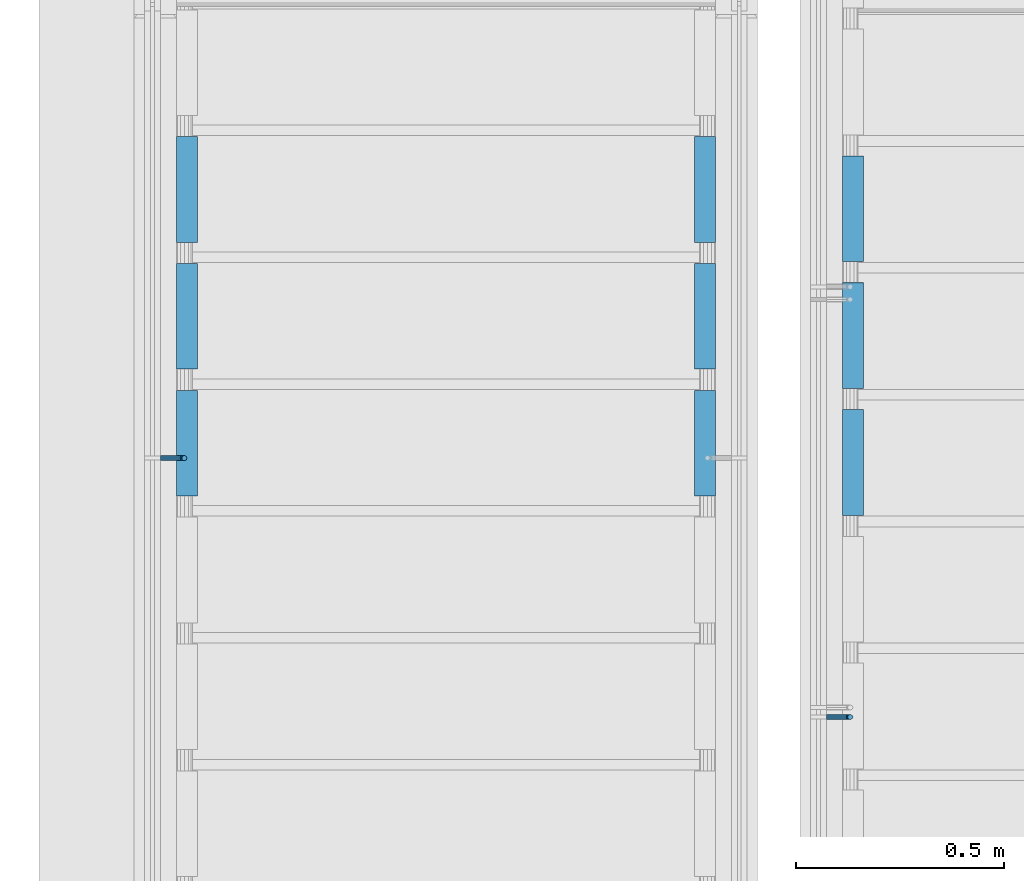
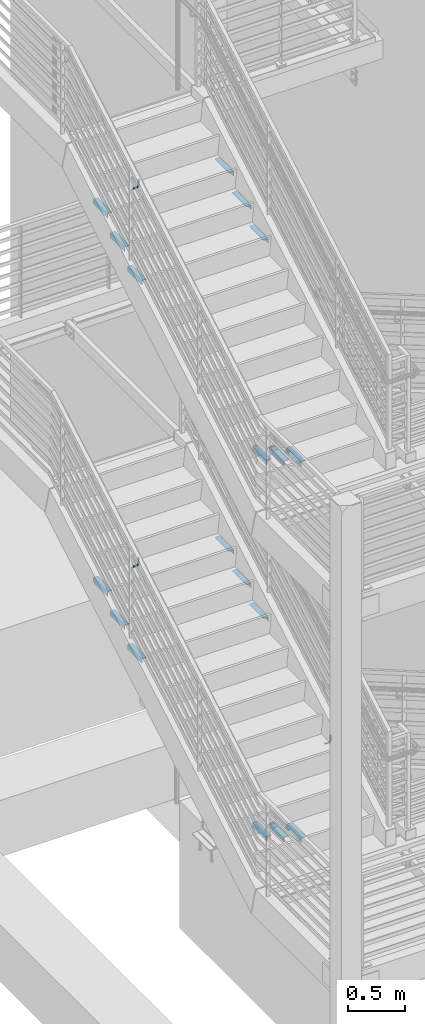
# One storey, part 861 of 1179: 21 beams, 7 elements without a shape of their own.
"""IFC2X3 building model written with IfcOpenShell, lengths in millimetres."""

from ifc_helpers import new_model, si_unit, frame, origin_with_axes, place, context, subcontext, project, spatial, faceted_brep, material, type_object, element, aggregate, save


model = new_model("IFC2X3")

# Units and contexts
model_context = context("Model", 3, precision=1e-05, world=origin_with_axes())
body_context = subcontext(model_context, "Body", "Model", "MODEL_VIEW")
ifc_project = project(units=[si_unit("LENGTHUNIT", "METRE", prefix="MILLI"), si_unit("AREAUNIT", "SQUARE_METRE"), si_unit("VOLUMEUNIT", "CUBIC_METRE"), si_unit("MASSUNIT", "GRAM", prefix="KILO"), si_unit("TIMEUNIT", "SECOND"), si_unit("PLANEANGLEUNIT", "RADIAN"), si_unit("SOLIDANGLEUNIT", "STERADIAN"), si_unit("THERMODYNAMICTEMPERATUREUNIT", "DEGREE_CELSIUS"), si_unit("LUMINOUSINTENSITYUNIT", "LUMEN")], contexts=[model_context])

# Site, building, storey
site_placement = place(None, origin_with_axes())
site = spatial("IfcSite", under=ifc_project, at=site_placement, CompositionType="ELEMENT")
building_placement = place(site_placement, origin_with_axes())
building = spatial("IfcBuilding", under=site, at=building_placement, Name="Undefined", CompositionType="ELEMENT")
storey_placement = place(building_placement, origin_with_axes())
storey = spatial("IfcBuildingStorey", under=building, at=storey_placement, Name="Undefined", CompositionType="ELEMENT", Elevation=0.0)

# Assembly, beams
assembly_1_placement = place(storey_placement, origin_with_axes())
assembly_1 = element("IfcElementAssembly", 1, at=assembly_1_placement, inside=storey, Name="STRINGER", AssemblyPlace="NOTDEFINED", PredefinedType="RIGID_FRAME")
ifc_material = material(Name="STEEL/A36")
beam_type_1 = type_object("IfcBeamType", Name="L2X2X3/16", PredefinedType="NOTDEFINED")
beam_1_placement = place(assembly_1_placement, frame((-3174.99999998093, 34376.6643775512, 7712.07500000067), z_axis=(1.0, 0.0, 0.0), x_axis=(0.0, 1.0, 0.0)))
beam_1 = element("IfcBeam", 2, at=beam_1_placement, type_object=beam_type_1, material=ifc_material, Name="ANGLE", ObjectType="L2X2X3/16", context=body_context, shape_type="Brep", body=[
    faceted_brep([(0.0, 25.3999999999996, -25.4000000000015), (0.0, 25.3999999999996, 25.4000000000015), (254.0, 25.3999999999996, 25.4000000000001), (254.0, 25.3999999999996, -25.4000000000001), (0.0, 20.6374999999998, 25.4000000000015), (254.0, 20.6374999999998, 25.4000000000001), (0.0, 20.6374999999998, -20.6374999999971), (254.0, 20.6374999999998, -20.6374999999998), (0.0, -25.3999999999996, -20.6374999999971), (254.0, -25.3999999999996, -20.6374999999998), (0.0, -25.3999999999996, -25.4000000000015), (254.0, -25.3999999999996, -25.4000000000001)], [[[0, 1, 2, 3]], [[1, 4, 5, 2]], [[4, 6, 7, 5]], [[6, 8, 9, 7]], [[8, 10, 11, 9]], [[10, 0, 3, 11]], [[5, 7, 9, 11, 3, 2]], [[10, 8, 6, 4, 1, 0]]]),
])
beam_2_placement = place(assembly_1_placement, frame((-1930.40000000014, 34630.6643775512, 7712.07499999954), z_axis=(-1.0, 0.0, 0.0), x_axis=(0.0, -1.0, 0.0)))
beam_2 = element("IfcBeam", 3, at=beam_2_placement, type_object=beam_type_1, material=ifc_material, Name="ANGLE", ObjectType="L2X2X3/16", context=body_context, shape_type="Brep", body=[
    faceted_brep([(0.0, 25.3999999999996, -25.4000000000015), (0.0, 25.3999999999996, 25.4000000000015), (254.0, 25.3999999999996, 25.4000000000001), (254.0, 25.3999999999996, -25.4000000000001), (0.0, 20.6374999999998, 25.4000000000015), (254.0, 20.6374999999998, 25.4000000000001), (0.0, 20.6374999999998, -20.6374999999971), (254.0, 20.6374999999998, -20.6374999999998), (0.0, -25.3999999999996, -20.6374999999971), (254.0, -25.3999999999996, -20.6374999999998), (0.0, -25.3999999999996, -25.4000000000015), (254.0, -25.3999999999996, -25.4000000000001)], [[[0, 1, 2, 3]], [[1, 4, 5, 2]], [[4, 6, 7, 5]], [[6, 8, 9, 7]], [[8, 10, 11, 9]], [[10, 0, 3, 11]], [[5, 7, 9, 11, 3, 2]], [[10, 8, 6, 4, 1, 0]]]),
])
beam_3_placement = place(assembly_1_placement, frame((-3174.99999998109, 34071.8643778032, 7534.27500000067), z_axis=(1.0, 0.0, 0.0), x_axis=(0.0, 1.0, 0.0)))
beam_3 = element("IfcBeam", 4, at=beam_3_placement, type_object=beam_type_1, material=ifc_material, Name="ANGLE", ObjectType="L2X2X3/16", context=body_context, shape_type="Brep", body=[
    faceted_brep([(0.0, 25.3999999999996, -25.4000000000015), (0.0, 25.3999999999996, 25.4000000000015), (254.0, 25.3999999999996, 25.4000000000001), (254.0, 25.3999999999996, -25.4000000000001), (0.0, 20.6374999999998, 25.4000000000015), (254.0, 20.6374999999998, 25.4000000000001), (0.0, 20.6374999999998, -20.6374999999971), (254.0, 20.6374999999998, -20.6374999999998), (0.0, -25.3999999999996, -20.6374999999971), (254.0, -25.3999999999996, -20.6374999999998), (0.0, -25.3999999999996, -25.4000000000015), (254.0, -25.3999999999996, -25.4000000000001)], [[[0, 1, 2, 3]], [[1, 4, 5, 2]], [[4, 6, 7, 5]], [[6, 8, 9, 7]], [[8, 10, 11, 9]], [[10, 0, 3, 11]], [[5, 7, 9, 11, 3, 2]], [[10, 8, 6, 4, 1, 0]]]),
])
beam_4_placement = place(assembly_1_placement, frame((-1930.4000000003, 34325.8643778032, 7534.27499999954), z_axis=(-1.0, 0.0, 0.0), x_axis=(0.0, -1.0, 0.0)))
beam_4 = element("IfcBeam", 5, at=beam_4_placement, type_object=beam_type_1, material=ifc_material, Name="ANGLE", ObjectType="L2X2X3/16", context=body_context, shape_type="Brep", body=[
    faceted_brep([(0.0, 25.3999999999996, -25.4000000000015), (0.0, 25.3999999999996, 25.4000000000015), (254.0, 25.3999999999996, 25.4000000000001), (254.0, 25.3999999999996, -25.4000000000001), (0.0, 20.6374999999998, 25.4000000000015), (254.0, 20.6374999999998, 25.4000000000001), (0.0, 20.6374999999998, -20.6374999999971), (254.0, 20.6374999999998, -20.6374999999998), (0.0, -25.3999999999996, -20.6374999999971), (254.0, -25.3999999999996, -20.6374999999998), (0.0, -25.3999999999996, -25.4000000000015), (254.0, -25.3999999999996, -25.4000000000001)], [[[0, 1, 2, 3]], [[1, 4, 5, 2]], [[4, 6, 7, 5]], [[6, 8, 9, 7]], [[8, 10, 11, 9]], [[10, 0, 3, 11]], [[5, 7, 9, 11, 3, 2]], [[10, 8, 6, 4, 1, 0]]]),
])
beam_5_placement = place(assembly_1_placement, frame((-3174.99999998125, 33767.0643780553, 7356.47500000067), z_axis=(1.0, 0.0, 0.0), x_axis=(0.0, 1.0, 0.0)))
beam_5 = element("IfcBeam", 6, at=beam_5_placement, type_object=beam_type_1, material=ifc_material, Name="ANGLE", ObjectType="L2X2X3/16", context=body_context, shape_type="Brep", body=[
    faceted_brep([(0.0, 25.3999999999996, -25.4000000000015), (0.0, 25.3999999999996, 25.4000000000015), (254.0, 25.3999999999996, 25.4000000000001), (254.0, 25.3999999999996, -25.4000000000001), (0.0, 20.6374999999998, 25.4000000000015), (254.0, 20.6374999999998, 25.4000000000001), (0.0, 20.6374999999998, -20.6374999999971), (254.0, 20.6374999999998, -20.6374999999998), (0.0, -25.3999999999996, -20.6374999999971), (254.0, -25.3999999999996, -20.6374999999998), (0.0, -25.3999999999996, -25.4000000000015), (254.0, -25.3999999999996, -25.4000000000001)], [[[0, 1, 2, 3]], [[1, 4, 5, 2]], [[4, 6, 7, 5]], [[6, 8, 9, 7]], [[8, 10, 11, 9]], [[10, 0, 3, 11]], [[5, 7, 9, 11, 3, 2]], [[10, 8, 6, 4, 1, 0]]]),
])
beam_6_placement = place(assembly_1_placement, frame((-1930.40000000046, 34021.0643780553, 7356.47499999954), z_axis=(-1.0, 0.0, 0.0), x_axis=(0.0, -1.0, 0.0)))
beam_6 = element("IfcBeam", 7, at=beam_6_placement, type_object=beam_type_1, material=ifc_material, Name="ANGLE", ObjectType="L2X2X3/16", context=body_context, shape_type="Brep", body=[
    faceted_brep([(0.0, 25.3999999999996, -25.4000000000015), (0.0, 25.3999999999996, 25.4000000000015), (254.0, 25.3999999999996, 25.4000000000001), (254.0, 25.3999999999996, -25.4000000000001), (0.0, 20.6374999999998, 25.4000000000015), (254.0, 20.6374999999998, 25.4000000000001), (0.0, 20.6374999999998, -20.6374999999971), (254.0, 20.6374999999998, -20.6374999999998), (0.0, -25.3999999999996, -20.6374999999971), (254.0, -25.3999999999996, -20.6374999999998), (0.0, -25.3999999999996, -25.4000000000015), (254.0, -25.3999999999996, -25.4000000000001)], [[[0, 1, 2, 3]], [[1, 4, 5, 2]], [[4, 6, 7, 5]], [[6, 8, 9, 7]], [[8, 10, 11, 9]], [[10, 0, 3, 11]], [[5, 7, 9, 11, 3, 2]], [[10, 8, 6, 4, 1, 0]]]),
])
aggregate(assembly_1, [beam_1, beam_2, beam_3, beam_4, beam_5, beam_6])

assembly_2_placement = place(storey_placement, origin_with_axes())
assembly_2 = element("IfcElementAssembly", 8, at=assembly_2_placement, inside=storey, Name="STRINGER", AssemblyPlace="NOTDEFINED", PredefinedType="RIGID_FRAME")
beam_7_placement = place(assembly_2_placement, frame((-1574.79999999983, 33720.7356224165, 4867.27499923021), z_axis=(1.0, 0.0, 0.0), x_axis=(0.0, 1.0, 0.0)))
beam_7 = element("IfcBeam", 9, at=beam_7_placement, type_object=beam_type_1, material=ifc_material, Name="ANGLE", ObjectType="L2X2X3/16", context=body_context, shape_type="Brep", body=[
    faceted_brep([(0.0, 25.3999999999996, -25.4000000000015), (0.0, 25.3999999999996, 25.4000000000015), (254.0, 25.3999999999996, 25.4000000000001), (254.0, 25.3999999999996, -25.4000000000001), (0.0, 20.6374999999998, 25.4000000000015), (254.0, 20.6374999999998, 25.4000000000001), (0.0, 20.6374999999998, -20.6374999999971), (254.0, 20.6374999999998, -20.6374999999998), (0.0, -25.3999999999996, -20.6374999999971), (254.0, -25.3999999999996, -20.6374999999998), (0.0, -25.3999999999996, -25.4000000000015), (254.0, -25.3999999999996, -25.4000000000001)], [[[0, 1, 2, 3]], [[1, 4, 5, 2]], [[4, 6, 7, 5]], [[6, 8, 9, 7]], [[8, 10, 11, 9]], [[10, 0, 3, 11]], [[5, 7, 9, 11, 3, 2]], [[10, 8, 6, 4, 1, 0]]]),
])
beam_8_placement = place(assembly_2_placement, frame((-1574.80000000188, 34025.5356223526, 4689.47499912051), z_axis=(1.0, 0.0, 0.0), x_axis=(0.0, 1.0, 0.0)))
beam_8 = element("IfcBeam", 10, at=beam_8_placement, type_object=beam_type_1, material=ifc_material, Name="ANGLE", ObjectType="L2X2X3/16", context=body_context, shape_type="Brep", body=[
    faceted_brep([(0.0, 25.3999999999996, -25.4000000000015), (0.0, 25.3999999999996, 25.4000000000015), (254.0, 25.3999999999996, 25.4000000000001), (254.0, 25.3999999999996, -25.4000000000001), (0.0, 20.6374999999998, 25.4000000000015), (254.0, 20.6374999999998, 25.4000000000001), (0.0, 20.6374999999998, -20.6374999999971), (254.0, 20.6374999999998, -20.6374999999998), (0.0, -25.3999999999996, -20.6374999999971), (254.0, -25.3999999999996, -20.6374999999998), (0.0, -25.3999999999996, -25.4000000000015), (254.0, -25.3999999999996, -25.4000000000001)], [[[0, 1, 2, 3]], [[1, 4, 5, 2]], [[4, 6, 7, 5]], [[6, 8, 9, 7]], [[8, 10, 11, 9]], [[10, 0, 3, 11]], [[5, 7, 9, 11, 3, 2]], [[10, 8, 6, 4, 1, 0]]]),
])
beam_9_placement = place(assembly_2_placement, frame((-1574.80000000394, 34330.3356222886, 4511.67499901081), z_axis=(1.0, 0.0, 0.0), x_axis=(0.0, 1.0, 0.0)))
beam_9 = element("IfcBeam", 11, at=beam_9_placement, type_object=beam_type_1, material=ifc_material, Name="ANGLE", ObjectType="L2X2X3/16", context=body_context, shape_type="Brep", body=[
    faceted_brep([(0.0, 25.3999999999996, -25.4000000000015), (0.0, 25.3999999999996, 25.4000000000015), (254.0, 25.3999999999996, 25.4000000000001), (254.0, 25.3999999999996, -25.4000000000001), (0.0, 20.6374999999998, 25.4000000000015), (254.0, 20.6374999999998, 25.4000000000001), (0.0, 20.6374999999998, -20.6374999999971), (254.0, 20.6374999999998, -20.6374999999998), (0.0, -25.3999999999996, -20.6374999999971), (254.0, -25.3999999999996, -20.6374999999998), (0.0, -25.3999999999996, -25.4000000000015), (254.0, -25.3999999999996, -25.4000000000001)], [[[0, 1, 2, 3]], [[1, 4, 5, 2]], [[4, 6, 7, 5]], [[6, 8, 9, 7]], [[8, 10, 11, 9]], [[10, 0, 3, 11]], [[5, 7, 9, 11, 3, 2]], [[10, 8, 6, 4, 1, 0]]]),
])
aggregate(assembly_2, [beam_7, beam_8, beam_9])

assembly_3_placement = place(storey_placement, origin_with_axes())
assembly_3 = element("IfcElementAssembly", 12, at=assembly_3_placement, inside=storey, Name="STRINGER", AssemblyPlace="NOTDEFINED", PredefinedType="RIGID_FRAME")
beam_10_placement = place(assembly_3_placement, frame((-1574.7999999795, 33720.6819391909, 803.029659879345), z_axis=(1.0, 0.0, 0.0), x_axis=(0.0, 1.0, 0.0)))
beam_10 = element("IfcBeam", 13, at=beam_10_placement, type_object=beam_type_1, material=ifc_material, Name="ANGLE", ObjectType="L2X2X3/16", context=body_context, shape_type="Brep", body=[
    faceted_brep([(0.0, 25.3999999999996, -25.4000000000015), (0.0, 25.3999999999996, 25.4000000000015), (254.0, 25.3999999999996, 25.4000000000001), (254.0, 25.3999999999996, -25.4000000000001), (0.0, 20.6374999999998, 25.4000000000015), (254.0, 20.6374999999998, 25.4000000000001), (0.0, 20.6374999999998, -20.6374999999971), (254.0, 20.6374999999998, -20.6374999999998), (0.0, -25.3999999999996, -20.6374999999971), (254.0, -25.3999999999996, -20.6374999999998), (0.0, -25.3999999999996, -25.4000000000015), (254.0, -25.3999999999996, -25.4000000000001)], [[[0, 1, 2, 3]], [[1, 4, 5, 2]], [[4, 6, 7, 5]], [[6, 8, 9, 7]], [[8, 10, 11, 9]], [[10, 0, 3, 11]], [[5, 7, 9, 11, 3, 2]], [[10, 8, 6, 4, 1, 0]]]),
])
beam_11_placement = place(assembly_3_placement, frame((-1574.79999997946, 34025.482092925, 626.547765742202), z_axis=(1.0, 0.0, 0.0), x_axis=(0.0, 1.0, 0.0)))
beam_11 = element("IfcBeam", 14, at=beam_11_placement, type_object=beam_type_1, material=ifc_material, Name="ANGLE", ObjectType="L2X2X3/16", context=body_context, shape_type="Brep", body=[
    faceted_brep([(0.0, 25.3999999999996, -25.4000000000015), (0.0, 25.3999999999996, 25.4000000000015), (254.0, 25.3999999999996, 25.4000000000001), (254.0, 25.3999999999996, -25.4000000000001), (0.0, 20.6374999999998, 25.4000000000015), (254.0, 20.6374999999998, 25.4000000000001), (0.0, 20.6374999999998, -20.6374999999971), (254.0, 20.6374999999998, -20.6374999999998), (0.0, -25.3999999999996, -20.6374999999971), (254.0, -25.3999999999996, -20.6374999999998), (0.0, -25.3999999999996, -25.4000000000015), (254.0, -25.3999999999996, -25.4000000000001)], [[[0, 1, 2, 3]], [[1, 4, 5, 2]], [[4, 6, 7, 5]], [[6, 8, 9, 7]], [[8, 10, 11, 9]], [[10, 0, 3, 11]], [[5, 7, 9, 11, 3, 2]], [[10, 8, 6, 4, 1, 0]]]),
])
beam_12_placement = place(assembly_3_placement, frame((-1574.79999997942, 34330.2822466591, 450.06587160506), z_axis=(1.0, 0.0, 0.0), x_axis=(0.0, 1.0, 0.0)))
beam_12 = element("IfcBeam", 15, at=beam_12_placement, type_object=beam_type_1, material=ifc_material, Name="ANGLE", ObjectType="L2X2X3/16", context=body_context, shape_type="Brep", body=[
    faceted_brep([(0.0, 25.3999999999996, -25.4000000000015), (0.0, 25.3999999999996, 25.4000000000015), (254.0, 25.3999999999996, 25.4000000000001), (254.0, 25.3999999999996, -25.4000000000001), (0.0, 20.6374999999998, 25.4000000000015), (254.0, 20.6374999999998, 25.4000000000001), (0.0, 20.6374999999998, -20.6374999999971), (254.0, 20.6374999999998, -20.6374999999998), (0.0, -25.3999999999996, -20.6374999999971), (254.0, -25.3999999999996, -20.6374999999998), (0.0, -25.3999999999996, -25.4000000000015), (254.0, -25.3999999999996, -25.4000000000001)], [[[0, 1, 2, 3]], [[1, 4, 5, 2]], [[4, 6, 7, 5]], [[6, 8, 9, 7]], [[8, 10, 11, 9]], [[10, 0, 3, 11]], [[5, 7, 9, 11, 3, 2]], [[10, 8, 6, 4, 1, 0]]]),
])
aggregate(assembly_3, [beam_10, beam_11, beam_12])

assembly_4_placement = place(storey_placement, origin_with_axes())
assembly_4 = element("IfcElementAssembly", 16, at=assembly_4_placement, inside=storey, Name="STRINGER", AssemblyPlace="NOTDEFINED", PredefinedType="RIGID_FRAME")
beam_13_placement = place(assembly_4_placement, frame((-3175.00000000384, 34376.719261414, 3626.64375000058), z_axis=(1.0, 0.0, 0.0), x_axis=(0.0, 1.0, 0.0)))
beam_13 = element("IfcBeam", 17, at=beam_13_placement, type_object=beam_type_1, material=ifc_material, Name="ANGLE", ObjectType="L2X2X3/16", context=body_context, shape_type="Brep", body=[
    faceted_brep([(0.0, 25.3999999999996, -25.4000000000015), (0.0, 25.3999999999996, 25.4000000000015), (254.0, 25.3999999999996, 25.4000000000001), (254.0, 25.3999999999996, -25.4000000000001), (0.0, 20.6374999999998, 25.4000000000015), (254.0, 20.6374999999998, 25.4000000000001), (0.0, 20.6374999999998, -20.6374999999971), (254.0, 20.6374999999998, -20.6374999999998), (0.0, -25.3999999999996, -20.6374999999971), (254.0, -25.3999999999996, -20.6374999999998), (0.0, -25.3999999999996, -25.4000000000015), (254.0, -25.3999999999996, -25.4000000000001)], [[[0, 1, 2, 3]], [[1, 4, 5, 2]], [[4, 6, 7, 5]], [[6, 8, 9, 7]], [[8, 10, 11, 9]], [[10, 0, 3, 11]], [[5, 7, 9, 11, 3, 2]], [[10, 8, 6, 4, 1, 0]]]),
])
beam_14_placement = place(assembly_4_placement, frame((-1930.40000000084, 34630.719261414, 3626.64375000058), z_axis=(-1.0, 0.0, 0.0), x_axis=(0.0, -1.0, 0.0)))
beam_14 = element("IfcBeam", 18, at=beam_14_placement, type_object=beam_type_1, material=ifc_material, Name="ANGLE", ObjectType="L2X2X3/16", context=body_context, shape_type="Brep", body=[
    faceted_brep([(0.0, 25.3999999999996, -25.4000000000015), (0.0, 25.3999999999996, 25.4000000000015), (254.0, 25.3999999999996, 25.4000000000001), (254.0, 25.3999999999996, -25.4000000000001), (0.0, 20.6374999999998, 25.4000000000015), (254.0, 20.6374999999998, 25.4000000000001), (0.0, 20.6374999999998, -20.6374999999971), (254.0, 20.6374999999998, -20.6374999999998), (0.0, -25.3999999999996, -20.6374999999971), (254.0, -25.3999999999996, -20.6374999999998), (0.0, -25.3999999999996, -25.4000000000015), (254.0, -25.3999999999996, -25.4000000000001)], [[[0, 1, 2, 3]], [[1, 4, 5, 2]], [[4, 6, 7, 5]], [[6, 8, 9, 7]], [[8, 10, 11, 9]], [[10, 0, 3, 11]], [[5, 7, 9, 11, 3, 2]], [[10, 8, 6, 4, 1, 0]]]),
])
beam_15_placement = place(assembly_4_placement, frame((-3175.00000000384, 34071.9192615033, 3450.16666666724), z_axis=(1.0, 0.0, 0.0), x_axis=(0.0, 1.0, 0.0)))
beam_15 = element("IfcBeam", 19, at=beam_15_placement, type_object=beam_type_1, material=ifc_material, Name="ANGLE", ObjectType="L2X2X3/16", context=body_context, shape_type="Brep", body=[
    faceted_brep([(0.0, 25.3999999999996, -25.4000000000015), (0.0, 25.3999999999996, 25.4000000000015), (254.0, 25.3999999999996, 25.4000000000001), (254.0, 25.3999999999996, -25.4000000000001), (0.0, 20.6374999999998, 25.4000000000015), (254.0, 20.6374999999998, 25.4000000000001), (0.0, 20.6374999999998, -20.6374999999971), (254.0, 20.6374999999998, -20.6374999999998), (0.0, -25.3999999999996, -20.6374999999971), (254.0, -25.3999999999996, -20.6374999999998), (0.0, -25.3999999999996, -25.4000000000015), (254.0, -25.3999999999996, -25.4000000000001)], [[[0, 1, 2, 3]], [[1, 4, 5, 2]], [[4, 6, 7, 5]], [[6, 8, 9, 7]], [[8, 10, 11, 9]], [[10, 0, 3, 11]], [[5, 7, 9, 11, 3, 2]], [[10, 8, 6, 4, 1, 0]]]),
])
beam_16_placement = place(assembly_4_placement, frame((-1930.40000000084, 34325.9192615033, 3450.16666666724), z_axis=(-1.0, 0.0, 0.0), x_axis=(0.0, -1.0, 0.0)))
beam_16 = element("IfcBeam", 20, at=beam_16_placement, type_object=beam_type_1, material=ifc_material, Name="ANGLE", ObjectType="L2X2X3/16", context=body_context, shape_type="Brep", body=[
    faceted_brep([(0.0, 25.3999999999996, -25.4000000000015), (0.0, 25.3999999999996, 25.4000000000015), (254.0, 25.3999999999996, 25.4000000000001), (254.0, 25.3999999999996, -25.4000000000001), (0.0, 20.6374999999998, 25.4000000000015), (254.0, 20.6374999999998, 25.4000000000001), (0.0, 20.6374999999998, -20.6374999999971), (254.0, 20.6374999999998, -20.6374999999998), (0.0, -25.3999999999996, -20.6374999999971), (254.0, -25.3999999999996, -20.6374999999998), (0.0, -25.3999999999996, -25.4000000000015), (254.0, -25.3999999999996, -25.4000000000001)], [[[0, 1, 2, 3]], [[1, 4, 5, 2]], [[4, 6, 7, 5]], [[6, 8, 9, 7]], [[8, 10, 11, 9]], [[10, 0, 3, 11]], [[5, 7, 9, 11, 3, 2]], [[10, 8, 6, 4, 1, 0]]]),
])
beam_17_placement = place(assembly_4_placement, frame((-3175.00000000384, 33767.1192615925, 3273.68958333391), z_axis=(1.0, 0.0, 0.0), x_axis=(0.0, 1.0, 0.0)))
beam_17 = element("IfcBeam", 21, at=beam_17_placement, type_object=beam_type_1, material=ifc_material, Name="ANGLE", ObjectType="L2X2X3/16", context=body_context, shape_type="Brep", body=[
    faceted_brep([(0.0, 25.3999999999996, -25.4000000000015), (0.0, 25.3999999999996, 25.4000000000015), (254.0, 25.3999999999996, 25.4000000000001), (254.0, 25.3999999999996, -25.4000000000001), (0.0, 20.6374999999998, 25.4000000000015), (254.0, 20.6374999999998, 25.4000000000001), (0.0, 20.6374999999998, -20.6374999999971), (254.0, 20.6374999999998, -20.6374999999998), (0.0, -25.3999999999996, -20.6374999999971), (254.0, -25.3999999999996, -20.6374999999998), (0.0, -25.3999999999996, -25.4000000000015), (254.0, -25.3999999999996, -25.4000000000001)], [[[0, 1, 2, 3]], [[1, 4, 5, 2]], [[4, 6, 7, 5]], [[6, 8, 9, 7]], [[8, 10, 11, 9]], [[10, 0, 3, 11]], [[5, 7, 9, 11, 3, 2]], [[10, 8, 6, 4, 1, 0]]]),
])
beam_18_placement = place(assembly_4_placement, frame((-1930.40000000084, 34021.1192615925, 3273.68958333391), z_axis=(-1.0, 0.0, 0.0), x_axis=(0.0, -1.0, 0.0)))
beam_18 = element("IfcBeam", 22, at=beam_18_placement, type_object=beam_type_1, material=ifc_material, Name="ANGLE", ObjectType="L2X2X3/16", context=body_context, shape_type="Brep", body=[
    faceted_brep([(0.0, 25.3999999999996, -25.4000000000015), (0.0, 25.3999999999996, 25.4000000000015), (254.0, 25.3999999999996, 25.4000000000001), (254.0, 25.3999999999996, -25.4000000000001), (0.0, 20.6374999999998, 25.4000000000015), (254.0, 20.6374999999998, 25.4000000000001), (0.0, 20.6374999999998, -20.6374999999971), (254.0, 20.6374999999998, -20.6374999999998), (0.0, -25.3999999999996, -20.6374999999971), (254.0, -25.3999999999996, -20.6374999999998), (0.0, -25.3999999999996, -25.4000000000015), (254.0, -25.3999999999996, -25.4000000000001)], [[[0, 1, 2, 3]], [[1, 4, 5, 2]], [[4, 6, 7, 5]], [[6, 8, 9, 7]], [[8, 10, 11, 9]], [[10, 0, 3, 11]], [[5, 7, 9, 11, 3, 2]], [[10, 8, 6, 4, 1, 0]]]),
])
aggregate(assembly_4, [beam_13, beam_14, beam_15, beam_16, beam_17, beam_18])

# Assembly, beam
assembly_5_placement = place(storey_placement, origin_with_axes())
assembly_5 = element("IfcElementAssembly", 23, at=assembly_5_placement, inside=storey, Name="GUARDRAIL", AssemblyPlace="NOTDEFINED", PredefinedType="RIGID_FRAME")
beam_type_2 = type_object("IfcBeamType", PredefinedType="NOTDEFINED")
beam_19_placement = place(assembly_5_placement, frame((-3238.49999995645, 33858.2000010808, 4250.13720348489), z_axis=(0.0, 0.0, 1.0), x_axis=(1.0, 0.0, 0.0)))
beam_19 = element("IfcBeam", 24, at=beam_19_placement, type_object=beam_type_2, material=ifc_material, Name="BRACKET", context=body_context, shape_type="Brep", body=[
    faceted_brep([(0.0, -4.49012806053361, 4.49012806053452), (0.0, 0.0, 6.34999999999991), (0.0, 4.49012806053361, 4.49012806053452), (0.0, 6.34999999999854, 0.0), (0.0, 4.49012806053361, -4.49012806053452), (0.0, 0.0, -6.34999999999991), (0.0, -4.49012806053361, -4.49012806053452), (0.0, -6.34999999999854, 0.0), (44.4500031699827, 0.0, -6.34999999999991), (44.4500031699827, -4.49012806053361, -4.49012806053452), (44.4500031699827, -6.34999999999854, 2.19733919948339e-09), (44.4500031699827, -4.49012806053361, 4.49012806053452), (44.4500031699827, 0.0, 6.34999999999991), (44.4500031699827, 4.49012806053361, 4.49012806053452), (44.4500031699827, 6.34999999999854, 0.0), (44.4500031699827, 4.49012806053361, -4.49012806053452), (53.0450671075391, 4.4901280570557, -2.18708762112465), (53.97500307462, -4.32919478043914e-09, -3.79778396764459), (53.0450671022344, -4.49012806401151, -2.1870876194389), (50.8000030708674, -6.35000000142099, 1.70147734757802), (48.5549390416977, -4.4901280599006, 5.59004231389645), (47.6250030746168, 1.48793333210051e-09, 7.20073866041594), (48.5549390470023, 4.49012806117025, 5.5900423122107), (50.8000030783693, 6.34999999857973, 1.70147734519378), (55.4485256393576, 6.34999999469437, 6.34999990618098), (59.337090604122, 4.49012805180246, 4.10493587545716), (51.5599606707875, 4.49012805866005, 8.59506393599531), (49.9492643188311, -4.54747350886464e-10, 9.52499990463002), (51.5599606615996, -4.4901280624108, 8.59506393379797), (55.4485256263639, -6.35000000530636, 6.34999990307369), (59.337090594938, -4.49012806926839, 4.10493587326664), (60.9477869468905, -1.0153598850593e-08, 3.17499990462466), (61.6401310450869, 4.49012804462109, 12.6999998130159), (63.5000029792477, -1.81098585017025e-08, 12.6999998092651), (57.1500029867496, 6.3499999893902, 12.6999998145698), (52.6598749240178, 4.49012805522943, 12.6999998130159), (50.8000029792477, -3.10683390125632e-09, 12.6999998092651), (52.6598749134085, -4.49012806583778, 12.6999998055144), (57.1500029739432, -6.35000001061053, 12.6999998039605), (61.6401310344776, -4.49012807644976, 12.6999998055144), (63.5000029792478, -6.94672053214163e-08, 76.1999999999989), (61.6401294880566, -4.49012904157644, 73.600247075432), (57.1500014109947, -6.35000090490212, 72.5233941775386), (52.6598733669871, -4.49012891616803, 73.6002471390625), (50.8000029792478, -5.78438630327582e-08, 76.1999999999989), (52.6598734909849, 4.49012713861157, 78.7997530334142), (57.150001576495, 6.34999900334878, 79.8766059321251), (61.6401296120544, 4.49012701602624, 78.7997529714175)], [[[0, 1, 2, 3, 4, 5, 6, 7]], [[6, 5, 8, 9]], [[7, 6, 9, 10]], [[0, 7, 10, 11]], [[1, 0, 11, 12]], [[2, 1, 12, 13]], [[3, 2, 13, 14]], [[4, 3, 14, 15]], [[5, 4, 15, 8]], [[8, 15, 16, 17]], [[9, 8, 17, 18]], [[10, 9, 18, 19]], [[11, 10, 19, 20]], [[12, 11, 20, 21]], [[13, 12, 21, 22]], [[14, 13, 22, 23]], [[15, 14, 23, 16]], [[23, 24, 25, 16]], [[22, 26, 24, 23]], [[21, 27, 26, 22]], [[20, 28, 27, 21]], [[19, 29, 28, 20]], [[18, 30, 29, 19]], [[17, 31, 30, 18]], [[16, 25, 31, 17]], [[25, 32, 33, 31]], [[24, 34, 32, 25]], [[26, 35, 34, 24]], [[27, 36, 35, 26]], [[28, 37, 36, 27]], [[29, 38, 37, 28]], [[30, 39, 38, 29]], [[31, 33, 39, 30]], [[39, 33, 40, 41]], [[38, 39, 41, 42]], [[37, 38, 42, 43]], [[36, 37, 43, 44]], [[35, 36, 44, 45]], [[34, 35, 45, 46]], [[32, 34, 46, 47]], [[33, 32, 47, 40]], [[46, 45, 44, 43, 42, 41, 40, 47]]]),
])
aggregate(assembly_5, [beam_19])

assembly_6_placement = place(storey_placement, origin_with_axes())
assembly_6 = element("IfcElementAssembly", 25, at=assembly_6_placement, inside=storey, Name="GUARDRAIL", AssemblyPlace="NOTDEFINED", PredefinedType="RIGID_FRAME")
beam_20_placement = place(assembly_6_placement, frame((-3238.49999995645, 33858.2000010815, 8333.48741133637), z_axis=(0.0, 0.0, 1.0), x_axis=(1.0, 0.0, 0.0)))
beam_20 = element("IfcBeam", 26, at=beam_20_placement, type_object=beam_type_2, material=ifc_material, Name="BRACKET", context=body_context, shape_type="Brep", body=[
    faceted_brep([(0.0, -4.49012806053361, 4.49012806053452), (0.0, 0.0, 6.34999999999991), (0.0, 4.49012806053361, 4.49012806053452), (0.0, 6.34999999999854, 0.0), (0.0, 4.49012806053361, -4.49012806053452), (0.0, 0.0, -6.34999999999991), (0.0, -4.49012806053361, -4.49012806053452), (0.0, -6.34999999999854, 0.0), (44.4500031699827, 0.0, -6.34999999999991), (44.4500031699827, -4.49012806053361, -4.49012806053452), (44.4500031699827, -6.34999999999854, 2.19733919948339e-09), (44.4500031699827, -4.49012806053361, 4.49012806053452), (44.4500031699827, 0.0, 6.34999999999991), (44.4500031699827, 4.49012806053361, 4.49012806053452), (44.4500031699827, 6.34999999999854, 0.0), (44.4500031699827, 4.49012806053361, -4.49012806053452), (53.0450671075391, 4.4901280570557, -2.18708762112465), (53.97500307462, -4.32919478043914e-09, -3.79778396764459), (53.0450671022344, -4.49012806401151, -2.1870876194389), (50.8000030708674, -6.35000000142099, 1.70147734757802), (48.5549390416977, -4.4901280599006, 5.59004231389645), (47.6250030746168, 1.48793333210051e-09, 7.20073866041594), (48.5549390470023, 4.49012806117025, 5.5900423122107), (50.8000030783693, 6.34999999857973, 1.70147734519378), (55.4485256393576, 6.34999999469437, 6.34999990618098), (59.337090604122, 4.49012805180246, 4.10493587545716), (51.5599606707875, 4.49012805866005, 8.59506393599531), (49.9492643188311, -4.54747350886464e-10, 9.52499990463002), (51.5599606615996, -4.4901280624108, 8.59506393379797), (55.4485256263639, -6.35000000530636, 6.34999990307369), (59.337090594938, -4.49012806926839, 4.10493587326664), (60.9477869468905, -1.0153598850593e-08, 3.17499990462466), (61.6401310450869, 4.49012804462109, 12.6999998130159), (63.5000029792477, -1.81098585017025e-08, 12.6999998092651), (57.1500029867496, 6.3499999893902, 12.6999998145698), (52.6598749240178, 4.49012805522943, 12.6999998130159), (50.8000029792477, -3.10683390125632e-09, 12.6999998092651), (52.6598749134085, -4.49012806583778, 12.6999998055144), (57.1500029739432, -6.35000001061053, 12.6999998039605), (61.6401310344776, -4.49012807644976, 12.6999998055144), (63.5000029792478, -6.94672053214163e-08, 76.1999999999989), (61.6401294880352, -4.49012904147821, 73.5807586715764), (57.1500014109847, -6.35000090467656, 72.4958334126568), (52.6598733669657, -4.49012891602615, 73.5807587357776), (50.8000029792478, -5.78438630327582e-08, 76.1999999999989), (52.6598734909962, 4.49012713825505, 78.8192414384375), (57.1500015765077, 6.34999900287221, 79.9041666981866), (61.6401296120657, 4.49012701564061, 78.8192413758952)], [[[0, 1, 2, 3, 4, 5, 6, 7]], [[6, 5, 8, 9]], [[7, 6, 9, 10]], [[0, 7, 10, 11]], [[1, 0, 11, 12]], [[2, 1, 12, 13]], [[3, 2, 13, 14]], [[4, 3, 14, 15]], [[5, 4, 15, 8]], [[8, 15, 16, 17]], [[9, 8, 17, 18]], [[10, 9, 18, 19]], [[11, 10, 19, 20]], [[12, 11, 20, 21]], [[13, 12, 21, 22]], [[14, 13, 22, 23]], [[15, 14, 23, 16]], [[23, 24, 25, 16]], [[22, 26, 24, 23]], [[21, 27, 26, 22]], [[20, 28, 27, 21]], [[19, 29, 28, 20]], [[18, 30, 29, 19]], [[17, 31, 30, 18]], [[16, 25, 31, 17]], [[25, 32, 33, 31]], [[24, 34, 32, 25]], [[26, 35, 34, 24]], [[27, 36, 35, 26]], [[28, 37, 36, 27]], [[29, 38, 37, 28]], [[30, 39, 38, 29]], [[31, 33, 39, 30]], [[39, 33, 40, 41]], [[38, 39, 41, 42]], [[37, 38, 42, 43]], [[36, 37, 43, 44]], [[35, 36, 44, 45]], [[34, 35, 45, 46]], [[32, 34, 46, 47]], [[33, 32, 47, 40]], [[46, 45, 44, 43, 42, 41, 40, 47]]]),
])
aggregate(assembly_6, [beam_20])

assembly_7_placement = place(storey_placement, origin_with_axes())
assembly_7 = element("IfcElementAssembly", 27, at=assembly_7_placement, inside=storey, Name="GUARDRAIL", AssemblyPlace="NOTDEFINED", PredefinedType="RIGID_FRAME")
beam_21_placement = place(assembly_7_placement, frame((-1638.3000007445, 33235.9000005577, 2154.50375592944), z_axis=(0.0, 0.0, 1.0), x_axis=(1.0, 0.0, 0.0)))
beam_21 = element("IfcBeam", 28, at=beam_21_placement, type_object=beam_type_2, material=ifc_material, Name="BRACKET", context=body_context, shape_type="Brep", body=[
    faceted_brep([(0.0, -4.49012806053361, 4.49012806053452), (0.0, 0.0, 6.34999999999991), (0.0, 4.49012806053361, 4.49012806053452), (0.0, 6.34999999999854, 0.0), (0.0, 4.49012806053361, -4.49012806053452), (0.0, 0.0, -6.34999999999991), (0.0, -4.49012806053361, -4.49012806053452), (0.0, -6.34999999999854, 0.0), (44.4500031699827, 0.0, -6.34999999999991), (44.4500031699827, -4.49012806053361, -4.49012806053452), (44.4500031699827, -6.34999999999854, 2.19733919948339e-09), (44.4500031699827, -4.49012806053361, 4.49012806053452), (44.4500031699827, 0.0, 6.34999999999991), (44.4500031699827, 4.49012806053361, 4.49012806053452), (44.4500031699827, 6.34999999999854, 0.0), (44.4500031699827, 4.49012806053361, -4.49012806053452), (53.0450671075391, 4.4901280570557, -2.18708762112465), (53.97500307462, -4.32919478043914e-09, -3.79778396764459), (53.0450671022344, -4.49012806401151, -2.1870876194389), (50.8000030708674, -6.35000000142099, 1.70147734757802), (48.5549390416977, -4.4901280599006, 5.59004231389645), (47.6250030746168, 1.48793333210051e-09, 7.20073866041594), (48.5549390470023, 4.49012806117025, 5.5900423122107), (50.8000030783693, 6.34999999857973, 1.70147734519378), (55.4485256393576, 6.34999999469437, 6.34999990618098), (59.337090604122, 4.49012805180246, 4.10493587545716), (51.5599606707875, 4.49012805866005, 8.59506393599531), (49.9492643188311, -4.54747350886464e-10, 9.52499990463002), (51.5599606615996, -4.4901280624108, 8.59506393379797), (55.4485256263639, -6.35000000530636, 6.34999990307369), (59.337090594938, -4.49012806926839, 4.10493587326664), (60.9477869468905, -1.0153598850593e-08, 3.17499990462466), (61.6401310450869, 4.49012804462109, 12.6999998130159), (63.5000029792477, -1.81098585017025e-08, 12.6999998092651), (57.1500029867496, 6.3499999893902, 12.6999998145698), (52.6598749240178, 4.49012805522943, 12.6999998130159), (50.8000029792477, -3.10683390125632e-09, 12.6999998092651), (52.6598749134085, -4.49012806583778, 12.6999998055144), (57.1500029739432, -6.35000001061053, 12.6999998039605), (61.6401310344776, -4.49012807644976, 12.6999998055144), (63.5000029792478, -6.94672053214163e-08, 76.1999999999989), (61.6401294941604, -4.49012902507093, 78.7998225171882), (57.150001417061, -6.35000092034534, 79.8767042410154), (52.6598733730912, -4.49012891187158, 78.7998224516436), (50.8000029792478, -5.78438630327582e-08, 76.1999999999989), (52.6598734875952, 4.4901272704119, 73.6001773671805), (57.1500015724957, 6.34999916438028, 72.5232956441077), (61.6401296086642, 4.49012715460412, 73.6001774342335)], [[[0, 1, 2, 3, 4, 5, 6, 7]], [[6, 5, 8, 9]], [[7, 6, 9, 10]], [[0, 7, 10, 11]], [[1, 0, 11, 12]], [[2, 1, 12, 13]], [[3, 2, 13, 14]], [[4, 3, 14, 15]], [[5, 4, 15, 8]], [[8, 15, 16, 17]], [[9, 8, 17, 18]], [[10, 9, 18, 19]], [[11, 10, 19, 20]], [[12, 11, 20, 21]], [[13, 12, 21, 22]], [[14, 13, 22, 23]], [[15, 14, 23, 16]], [[23, 24, 25, 16]], [[22, 26, 24, 23]], [[21, 27, 26, 22]], [[20, 28, 27, 21]], [[19, 29, 28, 20]], [[18, 30, 29, 19]], [[17, 31, 30, 18]], [[16, 25, 31, 17]], [[25, 32, 33, 31]], [[24, 34, 32, 25]], [[26, 35, 34, 24]], [[27, 36, 35, 26]], [[28, 37, 36, 27]], [[29, 38, 37, 28]], [[30, 39, 38, 29]], [[31, 33, 39, 30]], [[39, 33, 40, 41]], [[38, 39, 41, 42]], [[37, 38, 42, 43]], [[36, 37, 43, 44]], [[35, 36, 44, 45]], [[34, 35, 45, 46]], [[32, 34, 46, 47]], [[33, 32, 47, 40]], [[46, 45, 44, 43, 42, 41, 40, 47]]]),
])
aggregate(assembly_7, [beam_21])

save(model, "model.ifc")
